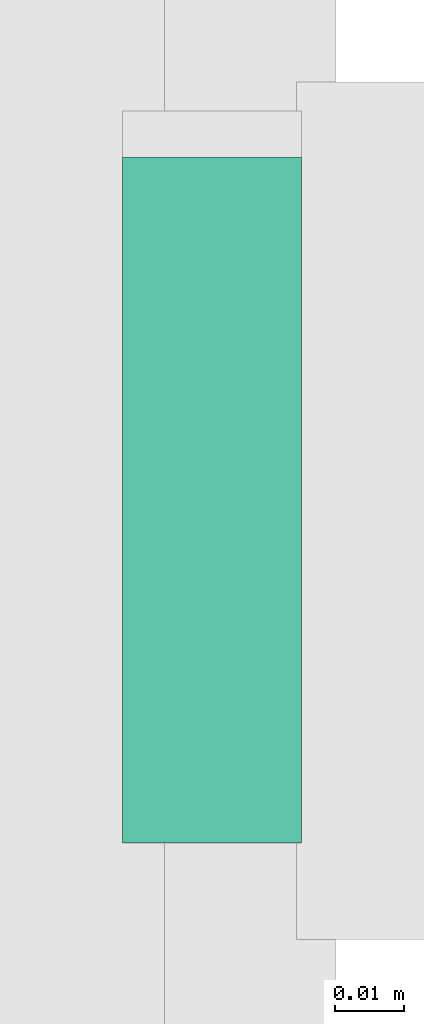
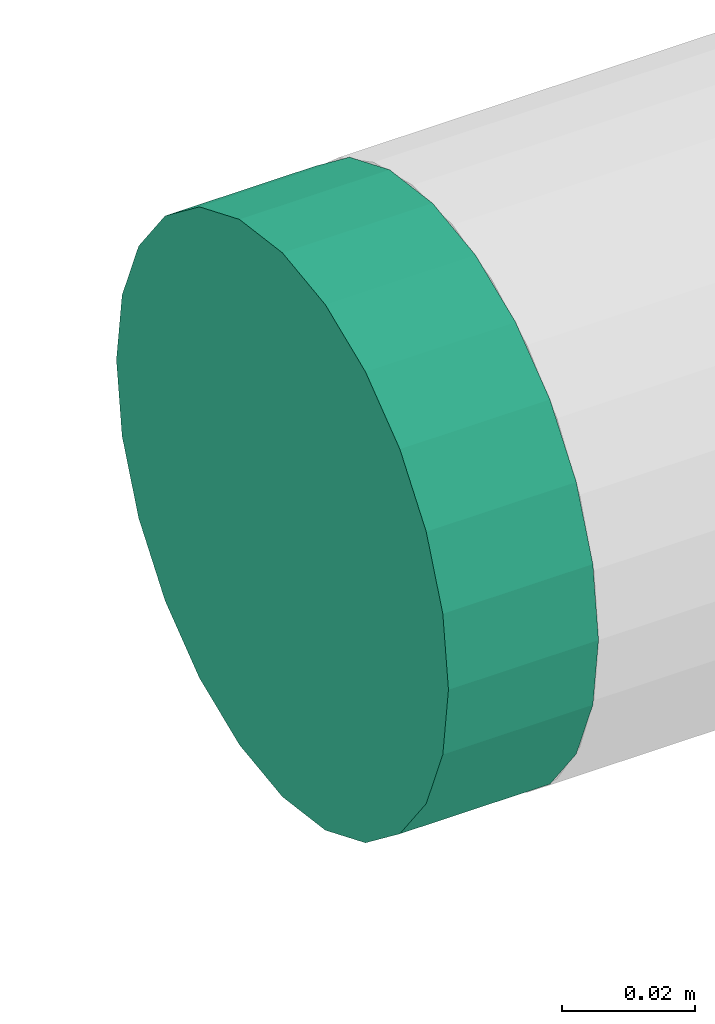
# One storey, part 237 of 337: 1 flow fitting.
"""IFC2X3 building model written with IfcOpenShell, lengths in millimetres."""

from ifc_helpers import new_model, entity, si_unit, converted_unit, derived_unit, direction, frame, origin, place, context, subcontext, project, spatial, faceted_brep, source, transform, mapped, material, type_object, type_shapes, element, save


model = new_model("IFC2X3")

# Units and contexts
model_context = context("Model", 3, precision=0.01, world=origin(), true_north=direction((6.12303176911189e-17, 1.0)))
body_context = subcontext(model_context, "Body", "Model", "MODEL_VIEW")
ifc_project = project(units=[si_unit("LENGTHUNIT", "METRE", prefix="MILLI"), si_unit("AREAUNIT", "SQUARE_METRE"), si_unit("VOLUMEUNIT", "CUBIC_METRE"), converted_unit("PLANEANGLEUNIT", "DEGREE", entity("IfcRatioMeasure", 0.0174532925199433), si_unit("PLANEANGLEUNIT", "RADIAN"), dimensions=[0, 0, 0, 0, 0, 0, 0]), si_unit("MASSUNIT", "GRAM", prefix="KILO"), derived_unit("MASSDENSITYUNIT", [(si_unit("MASSUNIT", "GRAM", prefix="KILO"), 1), (si_unit("LENGTHUNIT", "METRE"), -3)]), derived_unit("MOMENTOFINERTIAUNIT", [(si_unit("LENGTHUNIT", "METRE"), 4)]), si_unit("TIMEUNIT", "SECOND"), si_unit("FREQUENCYUNIT", "HERTZ"), si_unit("THERMODYNAMICTEMPERATUREUNIT", "DEGREE_CELSIUS"), derived_unit("THERMALTRANSMITTANCEUNIT", [(si_unit("MASSUNIT", "GRAM", prefix="KILO"), 1), (si_unit("THERMODYNAMICTEMPERATUREUNIT", "KELVIN"), -1), (si_unit("TIMEUNIT", "SECOND"), -3)]), derived_unit("VOLUMETRICFLOWRATEUNIT", [(si_unit("LENGTHUNIT", "METRE"), 3), (si_unit("TIMEUNIT", "SECOND"), -1)]), derived_unit("MASSFLOWRATEUNIT", [(si_unit("MASSUNIT", "GRAM", prefix="KILO"), 1), (si_unit("TIMEUNIT", "SECOND"), -1)]), derived_unit("ROTATIONALFREQUENCYUNIT", [(si_unit("TIMEUNIT", "SECOND"), -1)]), si_unit("ELECTRICCURRENTUNIT", "AMPERE"), si_unit("ELECTRICVOLTAGEUNIT", "VOLT"), si_unit("POWERUNIT", "WATT"), si_unit("FORCEUNIT", "NEWTON", prefix="KILO"), si_unit("ILLUMINANCEUNIT", "LUX"), si_unit("LUMINOUSFLUXUNIT", "LUMEN"), si_unit("LUMINOUSINTENSITYUNIT", "CANDELA"), derived_unit("USERDEFINED", [(si_unit("MASSUNIT", "GRAM", prefix="KILO"), -1), (si_unit("LENGTHUNIT", "METRE"), -2), (si_unit("TIMEUNIT", "SECOND"), 3), (si_unit("LUMINOUSFLUXUNIT", "LUMEN"), 1)]), derived_unit("LINEARVELOCITYUNIT", [(si_unit("LENGTHUNIT", "METRE"), 1), (si_unit("TIMEUNIT", "SECOND"), -1)]), si_unit("PRESSUREUNIT", "PASCAL"), derived_unit("USERDEFINED", [(si_unit("LENGTHUNIT", "METRE"), -2), (si_unit("MASSUNIT", "GRAM", prefix="KILO"), 1), (si_unit("TIMEUNIT", "SECOND"), -2)]), derived_unit("LINEARFORCEUNIT", [(si_unit("MASSUNIT", "GRAM", prefix="KILO"), 1), (si_unit("LENGTHUNIT", "METRE"), 1), (si_unit("TIMEUNIT", "SECOND"), -2), (si_unit("LENGTHUNIT", "METRE"), -1)]), derived_unit("PLANARFORCEUNIT", [(si_unit("MASSUNIT", "GRAM", prefix="KILO"), 1), (si_unit("LENGTHUNIT", "METRE"), 1), (si_unit("TIMEUNIT", "SECOND"), -2), (si_unit("LENGTHUNIT", "METRE"), -2)])], contexts=[model_context])

# Site, building, storey
site_placement = place(None, origin())
site = spatial("IfcSite", under=ifc_project, at=site_placement, CompositionType="ELEMENT")
building_placement = place(site_placement, origin())
building = spatial("IfcBuilding", under=site, at=building_placement, CompositionType="ELEMENT")
storey_placement = place(building_placement, origin())
storey = spatial("IfcBuildingStorey", under=building, at=storey_placement, CompositionType="ELEMENT", Elevation=0.0)

# Flow fitting
ifc_material = material()
duct_fitting_type = type_object("IfcDuctFittingType", PredefinedType="NOTDEFINED", material=ifc_material)
shared_shape = source(origin(), body_context, "Body", "Brep", [
    faceted_brep([(20.0, 12.94, -48.3), (20.0, 25.0, -43.3), (20.0, 35.36, -35.36), (20.0, 43.3, -25.0), (20.0, 48.3, -12.94), (20.0, 50.0, 0.0), (20.0, 48.3, 12.94), (20.0, 43.3, 25.0), (20.0, 35.36, 35.36), (20.0, 25.0, 43.3), (20.0, 12.94, 48.3), (20.0, 0.0, 50.0), (20.0, -12.94, 48.3), (20.0, -25.0, 43.3), (20.0, -35.36, 35.36), (20.0, -43.3, 25.0), (20.0, -48.3, 12.94), (20.0, -50.0, 0.0), (20.0, -48.3, -12.94), (20.0, -43.3, -25.0), (20.0, -35.36, -35.36), (20.0, -25.0, -43.3), (20.0, -12.94, -48.3), (20.0, 0.0, -50.0), (0.0, 0.0, 50.0), (0.0, 12.94, 48.3), (-6.1, 12.94, 48.3), (-6.1, 0.0, 50.0), (0.0, 25.0, 43.3), (-6.1, 25.0, 43.3), (0.0, 35.36, 35.36), (-6.1, 35.36, 35.36), (0.0, 43.3, 25.0), (0.0, 48.3, 12.94), (-6.1, 48.3, 12.94), (-6.1, 43.3, 25.0), (0.0, 50.0, 0.0), (-6.1, 50.0, 0.0), (0.0, 48.3, -12.94), (-6.1, 48.3, -12.94), (0.0, 43.3, -25.0), (-6.1, 43.3, -25.0), (0.0, 35.36, -35.36), (-6.1, 35.36, -35.36), (0.0, 25.0, -43.3), (0.0, 12.94, -48.3), (-6.1, 12.94, -48.3), (-6.1, 25.0, -43.3), (0.0, 0.0, -50.0), (-6.1, 0.0, -50.0), (0.0, -12.94, -48.3), (-6.1, -12.94, -48.3), (0.0, -25.0, -43.3), (-6.1, -25.0, -43.3), (0.0, -35.36, -35.36), (-6.1, -35.36, -35.36), (0.0, -43.3, -25.0), (0.0, -48.3, -12.94), (-6.1, -48.3, -12.94), (-6.1, -43.3, -25.0), (0.0, -50.0, 0.0), (-6.1, -50.0, 0.0), (0.0, -48.3, 12.94), (-6.1, -48.3, 12.94), (0.0, -43.3, 25.0), (-6.1, -43.3, 25.0), (0.0, -35.36, 35.36), (-6.1, -35.36, 35.36), (0.0, -25.0, 43.3), (0.0, -12.94, 48.3), (-6.1, -12.94, 48.3), (-6.1, -25.0, 43.3)], [[[0, 1, 2, 3, 4, 5, 6, 7, 8, 9, 10, 11, 12, 13, 14, 15, 16, 17, 18, 19, 20, 21, 22, 23]], [[24, 11, 10, 25, 26, 27]], [[25, 10, 9, 28, 29, 26]], [[28, 9, 8, 30, 31, 29]], [[32, 7, 6, 33, 34, 35]], [[33, 6, 5, 36, 37, 34]], [[30, 8, 7, 32, 35, 31]], [[36, 5, 4, 38, 39, 37]], [[38, 4, 3, 40, 41, 39]], [[40, 3, 2, 42, 43, 41]], [[44, 1, 0, 45, 46, 47]], [[45, 0, 23, 48, 49, 46]], [[42, 2, 1, 44, 47, 43]], [[48, 23, 22, 50, 51, 49]], [[50, 22, 21, 52, 53, 51]], [[52, 21, 20, 54, 55, 53]], [[56, 19, 18, 57, 58, 59]], [[57, 18, 17, 60, 61, 58]], [[54, 20, 19, 56, 59, 55]], [[60, 17, 16, 62, 63, 61]], [[62, 16, 15, 64, 65, 63]], [[64, 15, 14, 66, 67, 65]], [[68, 13, 12, 69, 70, 71]], [[69, 12, 11, 24, 27, 70]], [[66, 14, 13, 68, 71, 67]], [[49, 51, 53, 55, 59, 58, 61, 63, 65, 67, 71, 70, 27, 26, 29, 31, 35, 34, 37, 39, 41, 43, 47, 46]]]),
])
type_shapes(duct_fitting_type, [shared_shape])
flow_fitting_placement = place(storey_placement, frame((59655.69, 11807.44, 3450.0), z_axis=(0.0, -1.0, 0.0), x_axis=(1.0, 0.0, 0.0)))
element("IfcFlowFitting", 1, at=flow_fitting_placement, inside=storey, type_object=duct_fitting_type, material=ifc_material, context=body_context, shape_type="MappedRepresentation", body=[
    mapped(shared_shape, transform((0.0, 0.0, 0.0), scale=1.0)),
])

save(model, "model.ifc")
